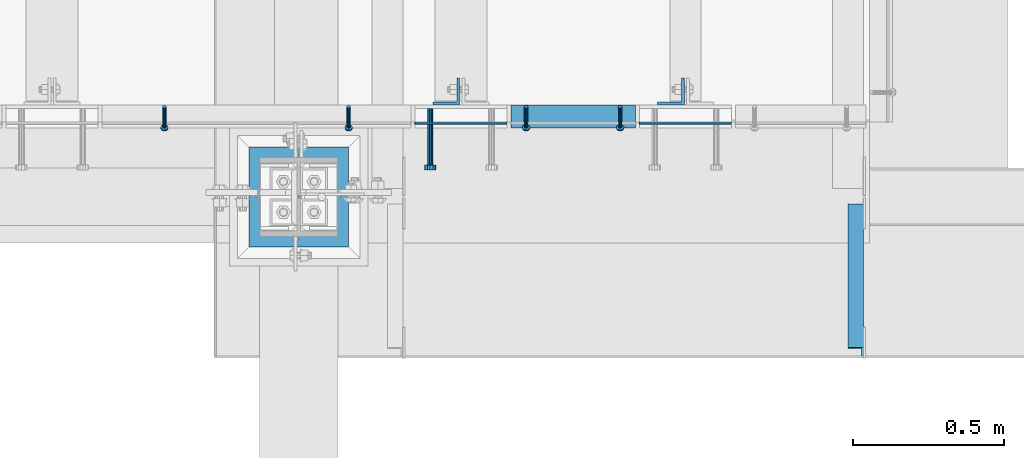
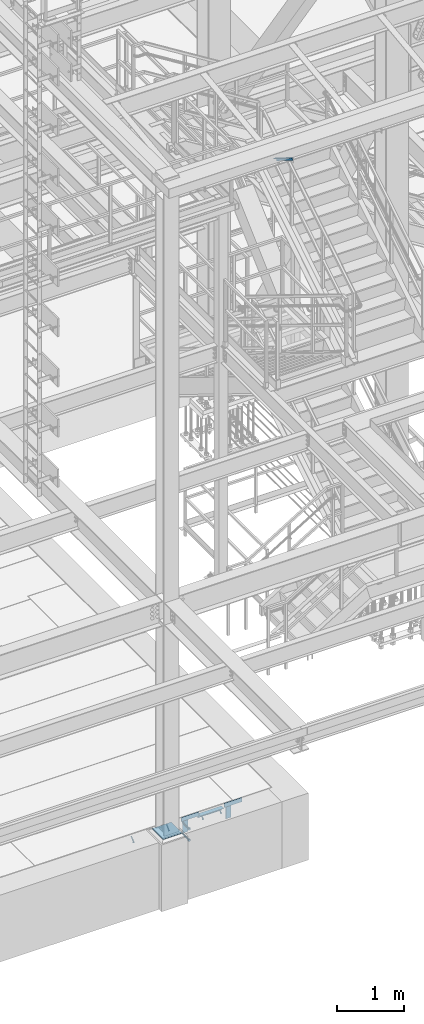
# One storey, part 2040 of 3843: 8 beams, 5 members, 8 elements without a shape of their own.
"""IFC2X3 building model written with IfcOpenShell, lengths in millimetres."""

from ifc_helpers import new_model, si_unit, frame, origin_with_axes, place, context, subcontext, project, spatial, faceted_brep, material, type_object, element, aggregate, save


model = new_model("IFC2X3")

# Units and contexts
model_context = context("Model", 3, precision=1e-05, world=origin_with_axes())
body_context = subcontext(model_context, "Body", "Model", "MODEL_VIEW")
ifc_project = project(units=[si_unit("LENGTHUNIT", "METRE", prefix="MILLI"), si_unit("AREAUNIT", "SQUARE_METRE"), si_unit("VOLUMEUNIT", "CUBIC_METRE"), si_unit("MASSUNIT", "GRAM", prefix="KILO"), si_unit("TIMEUNIT", "SECOND"), si_unit("PLANEANGLEUNIT", "RADIAN"), si_unit("SOLIDANGLEUNIT", "STERADIAN"), si_unit("THERMODYNAMICTEMPERATUREUNIT", "DEGREE_CELSIUS"), si_unit("LUMINOUSINTENSITYUNIT", "LUMEN")], contexts=[model_context])

# Site, building, storey
site_placement = place(None, origin_with_axes())
site = spatial("IfcSite", under=ifc_project, at=site_placement, CompositionType="ELEMENT")
building_placement = place(site_placement, origin_with_axes())
building = spatial("IfcBuilding", under=site, at=building_placement, Name="Undefined", CompositionType="ELEMENT")
storey_placement = place(building_placement, origin_with_axes())
storey = spatial("IfcBuildingStorey", under=building, at=storey_placement, Name="Undefined", CompositionType="ELEMENT", Elevation=0.0)

# Assembly, members
assembly_1_placement = place(storey_placement, origin_with_axes())
assembly_1 = element("IfcElementAssembly", 1, at=assembly_1_placement, inside=storey, Name="ANGLE", AssemblyPlace="NOTDEFINED", PredefinedType="RIGID_FRAME")
ifc_material_1 = material(Name="STEEL/A108")
member_type_1 = type_object("IfcMemberType", PredefinedType="NOTDEFINED")
member_1_placement = place(assembly_1_placement, frame((49161.7272929978, 15297.1500055596, 30397.4500030518), z_axis=(1.0, 0.0, 0.0), x_axis=(0.0, -0.707106781186548, -0.707106781186548)))
member_1 = element("IfcMember", 2, at=member_1_placement, type_object=member_type_1, material=ifc_material_1, Name="HEADED STUD ANCHOR", context=body_context, shape_type="Brep", body=[
    faceted_brep([(7.27595761418343e-12, -3.18000006675175, 5.5), (0.0, -5.49999999998363, 3.1800000667572), (94.4879985803855, -5.50000000011278, 3.1800000667572), (94.4879985803782, -3.18000006687362, 5.5), (0.0, -6.3499999046162, 0.0), (94.4879985803855, -6.34999990474535, 0.0), (0.0, -5.49999999998363, -3.1800000667572), (94.4879985803855, -5.50000000011278, -3.1800000667572), (7.27595761418343e-12, -3.18000006675175, -5.5), (94.4879985803782, -3.18000006687362, -5.5), (7.27595761418343e-12, -1.81898940354586e-12, -6.34999990463257), (94.4879985803782, -1.20053300634027e-10, -6.34999990463257), (0.0, 3.18000006675175, -5.5), (94.4879985803709, 3.18000006663351, -5.5), (7.27595761418343e-12, 5.49999999998363, -3.1800000667572), (94.4879985803709, 5.49999999987267, -3.1800000667572), (7.27595761418343e-12, 6.3499999046162, 0.0), (94.4879985803673, 6.34999990450706, 0.0), (7.27595761418343e-12, 5.49999999998363, 3.1800000667572), (94.4879985803709, 5.49999999987267, 3.1800000667572), (0.0, 3.18000006675175, 5.5), (94.4879985803709, 3.18000006663351, 5.5), (7.27595761418343e-12, -1.81898940354586e-12, 6.34999990463257), (94.4879985803782, -1.20053300634027e-10, 6.34999990463257), (96.5199985498621, -10.9899997712273, 6.34999990463257), (96.5199985498548, -6.34000015270249, 10.9899997711182), (96.5199985498621, -12.6999998093743, 0.0), (96.5199985498621, -10.9899997712273, -6.34999990463257), (96.5199985498548, -6.34000015270249, -10.9899997711182), (96.5199985498475, -1.21872290037572e-10, -12.6899995803833), (96.5199985498402, 6.34000015245874, -10.9899997711182), (96.519998549833, 10.9899997709817, -6.34999990463257), (96.519998549833, 12.6999998091305, 0.0), (96.519998549833, 10.9899997709817, 6.34999990463257), (96.5199985498402, 6.34000015245874, 10.9899997711182), (96.5199985498475, -1.21872290037572e-10, 12.6899995803833), (101.599998473539, -10.9899997712328, 6.34999990463257), (101.599998473532, -6.34000015270976, 10.9899997711182), (101.599998473539, -12.6999998093797, 0.0), (101.599998473539, -10.9899997712328, -6.34999990463257), (101.599998473532, -6.34000015270976, -10.9899997711182), (101.599998473524, -1.29148247651756e-10, -12.6899995803833), (101.599998473517, 6.34000015245329, -10.9899997711182), (101.59999847351, 10.9899997709763, -6.34999990463257), (101.599998473503, 12.6999998091196, 0.0), (101.59999847351, 10.9899997709763, 6.34999990463257), (101.599998473517, 6.34000015245329, 10.9899997711182), (101.599998473524, -1.29148247651756e-10, 12.6899995803833)], [[[0, 1, 2, 3]], [[1, 4, 5, 2]], [[4, 6, 7, 5]], [[6, 8, 9, 7]], [[8, 10, 11, 9]], [[10, 12, 13, 11]], [[12, 14, 15, 13]], [[14, 16, 17, 15]], [[16, 18, 19, 17]], [[18, 20, 21, 19]], [[20, 22, 23, 21]], [[22, 0, 3, 23]], [[22, 20, 18, 16, 14, 12, 10, 8, 6, 4, 1, 0]], [[3, 2, 24, 25]], [[2, 5, 26, 24]], [[5, 7, 27, 26]], [[7, 9, 28, 27]], [[9, 11, 29, 28]], [[11, 13, 30, 29]], [[13, 15, 31, 30]], [[15, 17, 32, 31]], [[17, 19, 33, 32]], [[19, 21, 34, 33]], [[21, 23, 35, 34]], [[23, 3, 25, 35]], [[25, 24, 36, 37]], [[24, 26, 38, 36]], [[26, 27, 39, 38]], [[27, 28, 40, 39]], [[28, 29, 41, 40]], [[29, 30, 42, 41]], [[30, 31, 43, 42]], [[31, 32, 44, 43]], [[32, 33, 45, 44]], [[33, 34, 46, 45]], [[34, 35, 47, 46]], [[35, 25, 37, 47]], [[38, 39, 40, 41, 42, 43, 44, 45, 46, 47, 37, 36]]]),
])
member_2_placement = place(assembly_1_placement, frame((48552.1272929978, 15297.1500055596, 30397.4500030518), z_axis=(1.0, 0.0, 0.0), x_axis=(0.0, -0.707106781186548, -0.707106781186548)))
member_2 = element("IfcMember", 3, at=member_2_placement, type_object=member_type_1, material=ifc_material_1, Name="HEADED STUD ANCHOR", context=body_context, shape_type="Brep", body=[
    faceted_brep([(7.27595761418343e-12, -3.18000006675175, 5.5), (0.0, -5.49999999998363, 3.1800000667572), (94.4879985803855, -5.50000000011278, 3.1800000667572), (94.4879985803782, -3.18000006687362, 5.5), (0.0, -6.3499999046162, 0.0), (94.4879985803855, -6.34999990474535, 0.0), (0.0, -5.49999999998363, -3.1800000667572), (94.4879985803855, -5.50000000011278, -3.1800000667572), (7.27595761418343e-12, -3.18000006675175, -5.5), (94.4879985803782, -3.18000006687362, -5.5), (7.27595761418343e-12, -1.81898940354586e-12, -6.34999990463257), (94.4879985803782, -1.20053300634027e-10, -6.34999990463257), (0.0, 3.18000006675175, -5.5), (94.4879985803709, 3.18000006663351, -5.5), (7.27595761418343e-12, 5.49999999998363, -3.1800000667572), (94.4879985803709, 5.49999999987267, -3.1800000667572), (7.27595761418343e-12, 6.3499999046162, 0.0), (94.4879985803673, 6.34999990450706, 0.0), (7.27595761418343e-12, 5.49999999998363, 3.1800000667572), (94.4879985803709, 5.49999999987267, 3.1800000667572), (0.0, 3.18000006675175, 5.5), (94.4879985803709, 3.18000006663351, 5.5), (7.27595761418343e-12, -1.81898940354586e-12, 6.34999990463257), (94.4879985803782, -1.20053300634027e-10, 6.34999990463257), (96.5199985498621, -10.9899997712273, 6.34999990463257), (96.5199985498548, -6.34000015270249, 10.9899997711182), (96.5199985498621, -12.6999998093743, 0.0), (96.5199985498621, -10.9899997712273, -6.34999990463257), (96.5199985498548, -6.34000015270249, -10.9899997711182), (96.5199985498475, -1.21872290037572e-10, -12.6899995803833), (96.5199985498402, 6.34000015245874, -10.9899997711182), (96.519998549833, 10.9899997709817, -6.34999990463257), (96.519998549833, 12.6999998091305, 0.0), (96.519998549833, 10.9899997709817, 6.34999990463257), (96.5199985498402, 6.34000015245874, 10.9899997711182), (96.5199985498475, -1.21872290037572e-10, 12.6899995803833), (101.599998473539, -10.9899997712328, 6.34999990463257), (101.599998473532, -6.34000015270976, 10.9899997711182), (101.599998473539, -12.6999998093797, 0.0), (101.599998473539, -10.9899997712328, -6.34999990463257), (101.599998473532, -6.34000015270976, -10.9899997711182), (101.599998473524, -1.29148247651756e-10, -12.6899995803833), (101.599998473517, 6.34000015245329, -10.9899997711182), (101.59999847351, 10.9899997709763, -6.34999990463257), (101.599998473503, 12.6999998091196, 0.0), (101.59999847351, 10.9899997709763, 6.34999990463257), (101.599998473517, 6.34000015245329, 10.9899997711182), (101.599998473524, -1.29148247651756e-10, 12.6899995803833)], [[[0, 1, 2, 3]], [[1, 4, 5, 2]], [[4, 6, 7, 5]], [[6, 8, 9, 7]], [[8, 10, 11, 9]], [[10, 12, 13, 11]], [[12, 14, 15, 13]], [[14, 16, 17, 15]], [[16, 18, 19, 17]], [[18, 20, 21, 19]], [[20, 22, 23, 21]], [[22, 0, 3, 23]], [[22, 20, 18, 16, 14, 12, 10, 8, 6, 4, 1, 0]], [[3, 2, 24, 25]], [[2, 5, 26, 24]], [[5, 7, 27, 26]], [[7, 9, 28, 27]], [[9, 11, 29, 28]], [[11, 13, 30, 29]], [[13, 15, 31, 30]], [[15, 17, 32, 31]], [[17, 19, 33, 32]], [[19, 21, 34, 33]], [[21, 23, 35, 34]], [[23, 3, 25, 35]], [[25, 24, 36, 37]], [[24, 26, 38, 36]], [[26, 27, 39, 38]], [[27, 28, 40, 39]], [[28, 29, 41, 40]], [[29, 30, 42, 41]], [[30, 31, 43, 42]], [[31, 32, 44, 43]], [[32, 33, 45, 44]], [[33, 34, 46, 45]], [[34, 35, 47, 46]], [[35, 25, 37, 47]], [[38, 39, 40, 41, 42, 43, 44, 45, 46, 47, 37, 36]]]),
])
aggregate(assembly_1, [member_1, member_2])

assembly_2_placement = place(storey_placement, origin_with_axes())
assembly_2 = element("IfcElementAssembly", 4, at=assembly_2_placement, inside=storey, Name="ANGLE", AssemblyPlace="NOTDEFINED", PredefinedType="RIGID_FRAME")
member_3_placement = place(assembly_2_placement, frame((49749.0749969224, 15297.1499857906, 30397.4500030518), z_axis=(1.0, 0.0, 0.0), x_axis=(0.0, -0.707106781186548, -0.707106781186548)))
member_3 = element("IfcMember", 5, at=member_3_placement, type_object=member_type_1, material=ifc_material_1, Name="HEADED STUD ANCHOR", context=body_context, shape_type="Brep", body=[
    faceted_brep([(7.27595761418343e-12, -3.18000006675175, 5.5), (0.0, -5.49999999998363, 3.1800000667572), (94.4879985803855, -5.50000000011278, 3.1800000667572), (94.4879985803782, -3.18000006687362, 5.5), (0.0, -6.3499999046162, 0.0), (94.4879985803855, -6.34999990474535, 0.0), (0.0, -5.49999999998363, -3.1800000667572), (94.4879985803855, -5.50000000011278, -3.1800000667572), (7.27595761418343e-12, -3.18000006675175, -5.5), (94.4879985803782, -3.18000006687362, -5.5), (7.27595761418343e-12, -1.81898940354586e-12, -6.34999990463257), (94.4879985803782, -1.20053300634027e-10, -6.34999990463257), (0.0, 3.18000006675175, -5.5), (94.4879985803709, 3.18000006663351, -5.5), (7.27595761418343e-12, 5.49999999998363, -3.1800000667572), (94.4879985803709, 5.49999999987267, -3.1800000667572), (7.27595761418343e-12, 6.3499999046162, 0.0), (94.4879985803673, 6.34999990450706, 0.0), (7.27595761418343e-12, 5.49999999998363, 3.1800000667572), (94.4879985803709, 5.49999999987267, 3.1800000667572), (0.0, 3.18000006675175, 5.5), (94.4879985803709, 3.18000006663351, 5.5), (7.27595761418343e-12, -1.81898940354586e-12, 6.34999990463257), (94.4879985803782, -1.20053300634027e-10, 6.34999990463257), (96.5199985498621, -10.9899997712273, 6.34999990463257), (96.5199985498548, -6.34000015270249, 10.9899997711182), (96.5199985498621, -12.6999998093743, 0.0), (96.5199985498621, -10.9899997712273, -6.34999990463257), (96.5199985498548, -6.34000015270249, -10.9899997711182), (96.5199985498475, -1.21872290037572e-10, -12.6899995803833), (96.5199985498402, 6.34000015245874, -10.9899997711182), (96.519998549833, 10.9899997709817, -6.34999990463257), (96.519998549833, 12.6999998091305, 0.0), (96.519998549833, 10.9899997709817, 6.34999990463257), (96.5199985498402, 6.34000015245874, 10.9899997711182), (96.5199985498475, -1.21872290037572e-10, 12.6899995803833), (101.599998473539, -10.9899997712328, 6.34999990463257), (101.599998473532, -6.34000015270976, 10.9899997711182), (101.599998473539, -12.6999998093797, 0.0), (101.599998473539, -10.9899997712328, -6.34999990463257), (101.599998473532, -6.34000015270976, -10.9899997711182), (101.599998473524, -1.29148247651756e-10, -12.6899995803833), (101.599998473517, 6.34000015245329, -10.9899997711182), (101.59999847351, 10.9899997709763, -6.34999990463257), (101.599998473503, 12.6999998091196, 0.0), (101.59999847351, 10.9899997709763, 6.34999990463257), (101.599998473517, 6.34000015245329, 10.9899997711182), (101.599998473524, -1.29148247651756e-10, 12.6899995803833)], [[[0, 1, 2, 3]], [[1, 4, 5, 2]], [[4, 6, 7, 5]], [[6, 8, 9, 7]], [[8, 10, 11, 9]], [[10, 12, 13, 11]], [[12, 14, 15, 13]], [[14, 16, 17, 15]], [[16, 18, 19, 17]], [[18, 20, 21, 19]], [[20, 22, 23, 21]], [[22, 0, 3, 23]], [[22, 20, 18, 16, 14, 12, 10, 8, 6, 4, 1, 0]], [[3, 2, 24, 25]], [[2, 5, 26, 24]], [[5, 7, 27, 26]], [[7, 9, 28, 27]], [[9, 11, 29, 28]], [[11, 13, 30, 29]], [[13, 15, 31, 30]], [[15, 17, 32, 31]], [[17, 19, 33, 32]], [[19, 21, 34, 33]], [[21, 23, 35, 34]], [[23, 3, 25, 35]], [[25, 24, 36, 37]], [[24, 26, 38, 36]], [[26, 27, 39, 38]], [[27, 28, 40, 39]], [[28, 29, 41, 40]], [[29, 30, 42, 41]], [[30, 31, 43, 42]], [[31, 32, 44, 43]], [[32, 33, 45, 44]], [[33, 34, 46, 45]], [[34, 35, 47, 46]], [[35, 25, 37, 47]], [[38, 39, 40, 41, 42, 43, 44, 45, 46, 47, 37, 36]]]),
])
member_4_placement = place(assembly_2_placement, frame((50060.2249969224, 15297.1499782818, 30397.4500030518), z_axis=(1.0, 0.0, 0.0), x_axis=(0.0, -0.707106781186548, -0.707106781186548)))
member_4 = element("IfcMember", 6, at=member_4_placement, type_object=member_type_1, material=ifc_material_1, Name="HEADED STUD ANCHOR", context=body_context, shape_type="Brep", body=[
    faceted_brep([(7.27595761418343e-12, -3.18000006675175, 5.5), (0.0, -5.49999999998363, 3.1800000667572), (94.4879985803855, -5.50000000011278, 3.1800000667572), (94.4879985803782, -3.18000006687362, 5.5), (0.0, -6.3499999046162, 0.0), (94.4879985803855, -6.34999990474535, 0.0), (0.0, -5.49999999998363, -3.1800000667572), (94.4879985803855, -5.50000000011278, -3.1800000667572), (7.27595761418343e-12, -3.18000006675175, -5.5), (94.4879985803782, -3.18000006687362, -5.5), (7.27595761418343e-12, -1.81898940354586e-12, -6.34999990463257), (94.4879985803782, -1.20053300634027e-10, -6.34999990463257), (0.0, 3.18000006675175, -5.5), (94.4879985803709, 3.18000006663351, -5.5), (7.27595761418343e-12, 5.49999999998363, -3.1800000667572), (94.4879985803709, 5.49999999987267, -3.1800000667572), (7.27595761418343e-12, 6.3499999046162, 0.0), (94.4879985803673, 6.34999990450706, 0.0), (7.27595761418343e-12, 5.49999999998363, 3.1800000667572), (94.4879985803709, 5.49999999987267, 3.1800000667572), (0.0, 3.18000006675175, 5.5), (94.4879985803709, 3.18000006663351, 5.5), (7.27595761418343e-12, -1.81898940354586e-12, 6.34999990463257), (94.4879985803782, -1.20053300634027e-10, 6.34999990463257), (96.5199985498621, -10.9899997712273, 6.34999990463257), (96.5199985498548, -6.34000015270249, 10.9899997711182), (96.5199985498621, -12.6999998093743, 0.0), (96.5199985498621, -10.9899997712273, -6.34999990463257), (96.5199985498548, -6.34000015270249, -10.9899997711182), (96.5199985498475, -1.21872290037572e-10, -12.6899995803833), (96.5199985498402, 6.34000015245874, -10.9899997711182), (96.519998549833, 10.9899997709817, -6.34999990463257), (96.519998549833, 12.6999998091305, 0.0), (96.519998549833, 10.9899997709817, 6.34999990463257), (96.5199985498402, 6.34000015245874, 10.9899997711182), (96.5199985498475, -1.21872290037572e-10, 12.6899995803833), (101.599998473539, -10.9899997712328, 6.34999990463257), (101.599998473532, -6.34000015270976, 10.9899997711182), (101.599998473539, -12.6999998093797, 0.0), (101.599998473539, -10.9899997712328, -6.34999990463257), (101.599998473532, -6.34000015270976, -10.9899997711182), (101.599998473524, -1.29148247651756e-10, -12.6899995803833), (101.599998473517, 6.34000015245329, -10.9899997711182), (101.59999847351, 10.9899997709763, -6.34999990463257), (101.599998473503, 12.6999998091196, 0.0), (101.59999847351, 10.9899997709763, 6.34999990463257), (101.599998473517, 6.34000015245329, 10.9899997711182), (101.599998473524, -1.29148247651756e-10, 12.6899995803833)], [[[0, 1, 2, 3]], [[1, 4, 5, 2]], [[4, 6, 7, 5]], [[6, 8, 9, 7]], [[8, 10, 11, 9]], [[10, 12, 13, 11]], [[12, 14, 15, 13]], [[14, 16, 17, 15]], [[16, 18, 19, 17]], [[18, 20, 21, 19]], [[20, 22, 23, 21]], [[22, 0, 3, 23]], [[22, 20, 18, 16, 14, 12, 10, 8, 6, 4, 1, 0]], [[3, 2, 24, 25]], [[2, 5, 26, 24]], [[5, 7, 27, 26]], [[7, 9, 28, 27]], [[9, 11, 29, 28]], [[11, 13, 30, 29]], [[13, 15, 31, 30]], [[15, 17, 32, 31]], [[17, 19, 33, 32]], [[19, 21, 34, 33]], [[21, 23, 35, 34]], [[23, 3, 25, 35]], [[25, 24, 36, 37]], [[24, 26, 38, 36]], [[26, 27, 39, 38]], [[27, 28, 40, 39]], [[28, 29, 41, 40]], [[29, 30, 42, 41]], [[30, 31, 43, 42]], [[31, 32, 44, 43]], [[32, 33, 45, 44]], [[33, 34, 46, 45]], [[34, 35, 47, 46]], [[35, 25, 37, 47]], [[38, 39, 40, 41, 42, 43, 44, 45, 46, 47, 37, 36]]]),
])

# Assembly, beam
assembly_3_placement = place(storey_placement, origin_with_axes())
assembly_3 = element("IfcElementAssembly", 7, at=assembly_3_placement, inside=storey, Name="EMBED PLATE", AssemblyPlace="NOTDEFINED", PredefinedType="RIGID_FRAME")
ifc_material_2 = material(Name="STEEL/A36")
beam_type_1 = type_object("IfcBeamType", PredefinedType="NOTDEFINED")
beam_1_placement = place(assembly_3_placement, frame((49685.575, 15243.1750030518, 30441.9), z_axis=(0.0, 0.0, 1.0), x_axis=(-1.0, 0.0, 0.0)))
beam_1 = element("IfcBeam", 8, at=beam_1_placement, type_object=beam_type_1, material=ifc_material_2, Name="PLATE", context=body_context, shape_type="Brep", body=[
    faceted_brep([(0.0, 3.17500000000291, -38.0999999999985), (0.0, 3.17500000000291, 38.0999999999985), (304.800000000003, 3.17499999999927, 38.0999999999985), (304.800000000003, 3.17499999999927, -38.0999999999985), (0.0, -3.17500000000291, 38.0999999999985), (304.800000000003, -3.17499999999927, 38.0999999999985), (0.0, -3.17500000000291, -38.0999999999985), (304.800000000003, -3.17499999999927, -38.0999999999985)], [[[0, 1, 2, 3]], [[1, 4, 5, 2]], [[4, 6, 7, 5]], [[6, 0, 3, 7]], [[5, 7, 3, 2]], [[6, 4, 1, 0]]]),
])

assembly_4_placement = place(storey_placement, origin_with_axes())
assembly_4 = element("IfcElementAssembly", 9, at=assembly_4_placement, inside=storey, Name="EMBED PLATE", AssemblyPlace="NOTDEFINED", PredefinedType="RIGID_FRAME")
beam_2_placement = place(assembly_4_placement, frame((50428.525, 15243.1750030518, 30441.9), z_axis=(0.0, 0.0, 1.0), x_axis=(-1.0, 0.0, 0.0)))
beam_2 = element("IfcBeam", 10, at=beam_2_placement, type_object=beam_type_1, material=ifc_material_2, Name="PLATE", context=body_context, shape_type="Brep", body=[
    faceted_brep([(0.0, 3.17500000000291, -38.0999999999985), (0.0, 3.17500000000291, 38.0999999999985), (304.800000000003, 3.17499999999927, 38.0999999999985), (304.800000000003, 3.17499999999927, -38.0999999999985), (0.0, -3.17500000000291, 38.0999999999985), (304.800000000003, -3.17499999999927, 38.0999999999985), (0.0, -3.17500000000291, -38.0999999999985), (304.800000000003, -3.17499999999927, -38.0999999999985)], [[[0, 1, 2, 3]], [[1, 4, 5, 2]], [[4, 6, 7, 5]], [[6, 0, 3, 7]], [[5, 7, 3, 2]], [[6, 4, 1, 0]]]),
])
aggregate(assembly_4, [beam_2])

# Assembly, member
assembly_5_placement = place(storey_placement, origin_with_axes())
assembly_5 = element("IfcElementAssembly", 11, at=assembly_5_placement, inside=storey, Name="ANGLE", AssemblyPlace="NOTDEFINED", PredefinedType="RIGID_FRAME")
ifc_material_3 = material(Name="STEEL/A572-50")
member_type_2 = type_object("IfcMemberType", Name="L2X2X1/4", PredefinedType="NOTDEFINED")
member_5_placement = place(assembly_5_placement, frame((50839.6875, 14962.4615149769, 42136.6100587905), z_axis=(-1.0, 0.0, 0.0), x_axis=(0.0, -0.851012521472712, 0.5251453972917)))
member_5 = element("IfcMember", 12, at=member_5_placement, type_object=member_type_2, material=ifc_material_3, Name="ANGLE", ObjectType="L2X2X1/4", context=body_context, shape_type="Brep", body=[
    faceted_brep([(0.0, 25.4000000000015, -25.4000000000015), (0.0, 25.4000000000015, 25.4000000000015), (558.799999999297, 25.3999999986918, 25.3999999999942), (558.799999999297, 25.3999999986918, -25.3999999999942), (0.0, 19.0500000000029, 25.4000000000015), (558.799999999297, 19.049999998686, 25.3999999999942), (0.0, 19.0500000000029, -19.0499999999993), (558.799999999297, 19.049999998686, -19.0500000000029), (0.0, -25.4000000000015, -19.0499999999993), (558.799999999281, -25.4000000013912, -19.0500000000029), (0.0, -25.4000000000015, -25.4000000000015), (558.799999999281, -25.4000000013912, -25.3999999999942)], [[[0, 1, 2, 3]], [[1, 4, 5, 2]], [[4, 6, 7, 5]], [[6, 8, 9, 7]], [[8, 10, 11, 9]], [[10, 0, 3, 11]], [[5, 7, 9, 11, 3, 2]], [[10, 8, 6, 4, 1, 0]]]),
])
aggregate(assembly_5, [member_5])

# Beam
beam_type_2 = type_object("IfcBeamType", Name="L3X3X1/4", PredefinedType="NOTDEFINED")
beam_3_placement = place(assembly_2_placement, frame((50111.0249771283, 15265.3999475479, 30365.7000030518), z_axis=(0.0, 0.0, -1.0), x_axis=(-1.0, 0.0, 0.0)))
beam_3 = element("IfcBeam", 13, at=beam_3_placement, type_object=beam_type_2, material=ifc_material_2, Name="ANGLE", ObjectType="L3X3X1/4", context=body_context, shape_type="Brep", body=[
    faceted_brep([(0.0, 38.0999999999985, -38.0999999999985), (0.0, 38.0999999999985, 38.0999999999985), (412.750000001892, 38.0999999996438, 38.0999999999985), (412.750000001892, 38.0999999996438, -38.0999999999985), (0.0, 31.75, 38.0999999999985), (412.75000000187, 31.7499999996417, 38.0999999999985), (0.0, 31.75, -31.75), (412.75000000187, 31.7499999996417, -31.75), (0.0, -38.0999999999985, -31.75), (412.750000001688, -38.1000000003733, -31.75), (0.0, -38.0999999999985, -38.0999999999985), (412.750000001688, -38.1000000003733, -38.0999999999985)], [[[0, 1, 2, 3]], [[1, 4, 5, 2]], [[4, 6, 7, 5]], [[6, 8, 9, 7]], [[8, 10, 11, 9]], [[10, 0, 3, 11]], [[5, 7, 9, 11, 3, 2]], [[10, 8, 6, 4, 1, 0]]]),
])

aggregate(assembly_2, [member_3, member_4, beam_3])

# Assembly, beam
assembly_6_placement = place(storey_placement, origin_with_axes())
assembly_6 = element("IfcElementAssembly", 14, at=assembly_6_placement, inside=storey, Name="BEAM", AssemblyPlace="NOTDEFINED", PredefinedType="RIGID_FRAME")
beam_type_3 = type_object("IfcBeamType", Name="L3-1/2X3-1/2X3/8", PredefinedType="NOTDEFINED")
beam_4_placement = place(assembly_6_placement, frame((50228.5, 15347.9500030518, 30365.7), z_axis=(-1.0, 0.0, 0.0), x_axis=(0.0, 0.0, -1.0)))
beam_4 = element("IfcBeam", 15, at=beam_4_placement, type_object=beam_type_3, material=ifc_material_2, Name="ANGLE", ObjectType="L3-1/2X3-1/2X3/8", context=body_context, shape_type="Brep", body=[
    faceted_brep([(-3.63797880709171e-12, 44.4499999999971, -44.4500000000007), (-3.63797880709171e-12, 44.4499999999971, 44.4500000000007), (228.600000000006, 44.4499999999971, 44.4500000000007), (228.600000000006, 44.4499999999971, -44.4500000000007), (0.0, 34.9250000000029, 44.4500000000007), (228.600000000006, 34.9250000000029, 44.4500000000007), (0.0, 34.9250000000029, -34.9250000000029), (228.600000000006, 34.9250000000029, -34.9249999999993), (0.0, -44.4499999999971, -34.9249999999993), (228.600000000006, -44.4499999999971, -34.9249999999993), (3.63797880709171e-12, -44.4499999999971, -44.4500000000007), (228.600000000006, -44.4499999999971, -44.4500000000007)], [[[0, 1, 2, 3]], [[1, 4, 5, 2]], [[4, 6, 7, 5]], [[6, 8, 9, 7]], [[8, 10, 11, 9]], [[10, 0, 3, 11]], [[5, 7, 9, 11, 3, 2]], [[10, 8, 6, 4, 1, 0]]]),
])
aggregate(assembly_6, [beam_4])

assembly_7_placement = place(storey_placement, origin_with_axes())
assembly_7 = element("IfcElementAssembly", 16, at=assembly_7_placement, inside=storey, Name="BEAM", AssemblyPlace="NOTDEFINED", PredefinedType="RIGID_FRAME")
beam_5_placement = place(assembly_7_placement, frame((49484.75625, 15347.9500030518, 30365.7), z_axis=(-1.0, 0.0, 0.0), x_axis=(0.0, 0.0, -1.0)))
beam_5 = element("IfcBeam", 17, at=beam_5_placement, type_object=beam_type_3, material=ifc_material_2, Name="ANGLE", ObjectType="L3-1/2X3-1/2X3/8", context=body_context, shape_type="Brep", body=[
    faceted_brep([(-3.63797880709171e-12, 44.4499999999971, -44.4500000000007), (-3.63797880709171e-12, 44.4499999999971, 44.4500000000007), (228.600000000006, 44.4499999999971, 44.4500000000007), (228.600000000006, 44.4499999999971, -44.4500000000007), (0.0, 34.9250000000029, 44.4500000000007), (228.600000000006, 34.9250000000029, 44.4500000000007), (0.0, 34.9250000000029, -34.9250000000029), (228.600000000006, 34.9250000000029, -34.9249999999993), (0.0, -44.4499999999971, -34.9249999999993), (228.600000000006, -44.4499999999971, -34.9249999999993), (3.63797880709171e-12, -44.4499999999971, -44.4500000000007), (228.600000000006, -44.4499999999971, -44.4500000000007)], [[[0, 1, 2, 3]], [[1, 4, 5, 2]], [[4, 6, 7, 5]], [[6, 8, 9, 7]], [[8, 10, 11, 9]], [[10, 0, 3, 11]], [[5, 7, 9, 11, 3, 2]], [[10, 8, 6, 4, 1, 0]]]),
])
aggregate(assembly_7, [beam_5])

# Beam
beam_type_4 = type_object("IfcBeamType", PredefinedType="NOTDEFINED")
beam_6_placement = place(assembly_3_placement, frame((49431.575, 15290.8000030518, 30346.65), z_axis=(1.0, 0.0, 0.0), x_axis=(0.0, -1.0, 0.0)))
beam_6 = element("IfcBeam", 18, at=beam_6_placement, type_object=beam_type_4, material=ifc_material_2, Name="PLATE", context=body_context, shape_type="Brep", body=[
    faceted_brep([(0.0, -9.52000045776367, 0.0), (0.0, -8.25, -4.76000022888184), (184.912000000004, -8.25, -4.76000022888184), (184.912000000004, -9.52000045776367, 0.0), (0.0, -4.76000022888184, -8.25), (184.912000000004, -4.76000022888184, -8.25), (0.0, 0.0, -9.52000045776367), (184.912000000004, 0.0, -9.52000045776367), (0.0, 4.76000022888184, -8.25), (184.912000000004, 4.76000022888184, -8.25), (0.0, 8.25, -4.76000022888184), (184.912000000004, 8.25, -4.76000022888184), (0.0, 9.52000045776367, 0.0), (184.912000000004, 9.52000045776367, 0.0), (0.0, 8.25, 4.76000022888184), (184.912000000004, 8.25, 4.76000022888184), (0.0, 4.76000022888184, 8.25), (184.912000000004, 4.76000022888184, 8.25), (0.0, 0.0, 9.52000045776367), (184.912000000004, 0.0, 9.52000045776367), (0.0, -4.76000022888184, 8.25), (184.912000000004, -4.76000022888184, 8.25), (0.0, -8.25, 4.76000022888184), (184.912000000004, -8.25, 4.76000022888184), (186.944000000003, -16.5, -9.52000045776367), (186.944000000003, -19.0499992370605, 0.0), (186.944000000003, -9.52000045776367, -16.5), (186.944000000003, 0.0, -19.0499992370605), (186.944000000003, 9.52000045776367, -16.5), (186.944000000003, 16.5, -9.52000045776367), (186.944000000003, 19.0499992370605, 0.0), (186.944000000003, 16.5, 9.52000045776367), (186.944000000003, 9.52000045776367, 16.5), (186.944000000003, 0.0, 19.0499992370605), (186.944000000003, -9.52000045776367, 16.5), (186.944000000003, -16.5, 9.52000045776367), (203.199999999997, -16.5, -9.52000045776367), (203.199999999997, -19.0499992370605, 0.0), (203.199999999997, -9.52000045776367, -16.5), (203.199999999997, 0.0, -19.0499992370605), (203.199999999997, 9.52000045776367, -16.5), (203.199999999997, 16.5, -9.52000045776367), (203.199999999997, 19.0499992370605, 0.0), (203.199999999997, 16.5, 9.52000045776367), (203.199999999997, 9.52000045776367, 16.5), (203.199999999997, 0.0, 19.0499992370605), (203.199999999997, -9.52000045776367, 16.5), (203.199999999997, -16.5, 9.52000045776367)], [[[0, 1, 2, 3]], [[1, 4, 5, 2]], [[4, 6, 7, 5]], [[6, 8, 9, 7]], [[8, 10, 11, 9]], [[10, 12, 13, 11]], [[12, 14, 15, 13]], [[14, 16, 17, 15]], [[16, 18, 19, 17]], [[18, 20, 21, 19]], [[20, 22, 23, 21]], [[22, 0, 3, 23]], [[22, 20, 18, 16, 14, 12, 10, 8, 6, 4, 1, 0]], [[3, 2, 24, 25]], [[2, 5, 26, 24]], [[5, 7, 27, 26]], [[7, 9, 28, 27]], [[9, 11, 29, 28]], [[11, 13, 30, 29]], [[13, 15, 31, 30]], [[15, 17, 32, 31]], [[17, 19, 33, 32]], [[19, 21, 34, 33]], [[21, 23, 35, 34]], [[23, 3, 25, 35]], [[25, 24, 36, 37]], [[24, 26, 38, 36]], [[26, 27, 39, 38]], [[27, 28, 40, 39]], [[28, 29, 41, 40]], [[29, 30, 42, 41]], [[30, 31, 43, 42]], [[31, 32, 44, 43]], [[32, 33, 45, 44]], [[33, 34, 46, 45]], [[34, 35, 47, 46]], [[35, 25, 37, 47]], [[38, 39, 40, 41, 42, 43, 44, 45, 46, 47, 37, 36]]]),
])

beam_7_placement = place(assembly_3_placement, frame((49431.575, 15290.8000030518, 30143.45), z_axis=(1.0, 0.0, 0.0), x_axis=(0.0, -1.0, 0.0)))
beam_7 = element("IfcBeam", 19, at=beam_7_placement, type_object=beam_type_4, material=ifc_material_1, Name="HEADED STUD ANCHOR", context=body_context, shape_type="Brep", body=[
    faceted_brep([(0.0, -9.52000045776367, 0.0), (0.0, -8.25, -4.76000022888184), (184.912000000004, -8.25, -4.76000022888184), (184.912000000004, -9.52000045776367, 0.0), (0.0, -4.76000022888184, -8.25), (184.912000000004, -4.76000022888184, -8.25), (0.0, 0.0, -9.52000045776367), (184.912000000004, 0.0, -9.52000045776367), (0.0, 4.76000022888184, -8.25), (184.912000000004, 4.76000022888184, -8.25), (0.0, 8.25, -4.76000022888184), (184.912000000004, 8.25, -4.76000022888184), (0.0, 9.52000045776367, 0.0), (184.912000000004, 9.52000045776367, 0.0), (0.0, 8.25, 4.76000022888184), (184.912000000004, 8.25, 4.76000022888184), (0.0, 4.76000022888184, 8.25), (184.912000000004, 4.76000022888184, 8.25), (0.0, 0.0, 9.52000045776367), (184.912000000004, 0.0, 9.52000045776367), (0.0, -4.76000022888184, 8.25), (184.912000000004, -4.76000022888184, 8.25), (0.0, -8.25, 4.76000022888184), (184.912000000004, -8.25, 4.76000022888184), (186.944000000003, -16.5, -9.52000045776367), (186.944000000003, -19.0499992370605, 0.0), (186.944000000003, -9.52000045776367, -16.5), (186.944000000003, 0.0, -19.0499992370605), (186.944000000003, 9.52000045776367, -16.5), (186.944000000003, 16.5, -9.52000045776367), (186.944000000003, 19.0499992370605, 0.0), (186.944000000003, 16.5, 9.52000045776367), (186.944000000003, 9.52000045776367, 16.5), (186.944000000003, 0.0, 19.0499992370605), (186.944000000003, -9.52000045776367, 16.5), (186.944000000003, -16.5, 9.52000045776367), (203.199999999997, -16.5, -9.52000045776367), (203.199999999997, -19.0499992370605, 0.0), (203.199999999997, -9.52000045776367, -16.5), (203.199999999997, 0.0, -19.0499992370605), (203.199999999997, 9.52000045776367, -16.5), (203.199999999997, 16.5, -9.52000045776367), (203.199999999997, 19.0499992370605, 0.0), (203.199999999997, 16.5, 9.52000045776367), (203.199999999997, 9.52000045776367, 16.5), (203.199999999997, 0.0, 19.0499992370605), (203.199999999997, -9.52000045776367, 16.5), (203.199999999997, -16.5, 9.52000045776367)], [[[0, 1, 2, 3]], [[1, 4, 5, 2]], [[4, 6, 7, 5]], [[6, 8, 9, 7]], [[8, 10, 11, 9]], [[10, 12, 13, 11]], [[12, 14, 15, 13]], [[14, 16, 17, 15]], [[16, 18, 19, 17]], [[18, 20, 21, 19]], [[20, 22, 23, 21]], [[22, 0, 3, 23]], [[22, 20, 18, 16, 14, 12, 10, 8, 6, 4, 1, 0]], [[3, 2, 24, 25]], [[2, 5, 26, 24]], [[5, 7, 27, 26]], [[7, 9, 28, 27]], [[9, 11, 29, 28]], [[11, 13, 30, 29]], [[13, 15, 31, 30]], [[15, 17, 32, 31]], [[17, 19, 33, 32]], [[19, 21, 34, 33]], [[21, 23, 35, 34]], [[23, 3, 25, 35]], [[25, 24, 36, 37]], [[24, 26, 38, 36]], [[26, 27, 39, 38]], [[27, 28, 40, 39]], [[28, 29, 41, 40]], [[29, 30, 42, 41]], [[30, 31, 43, 42]], [[31, 32, 44, 43]], [[32, 33, 45, 44]], [[33, 34, 46, 45]], [[34, 35, 47, 46]], [[35, 25, 37, 47]], [[38, 39, 40, 41, 42, 43, 44, 45, 46, 47, 37, 36]]]),
])

aggregate(assembly_3, [beam_1, beam_6, beam_7])

# Assembly, beam
assembly_8_placement = place(storey_placement, origin_with_axes())
assembly_8 = element("IfcElementAssembly", 20, at=assembly_8_placement, inside=storey, Name="TEMPLATE", AssemblyPlace="NOTDEFINED", PredefinedType="RIGID_FRAME")
beam_type_5 = type_object("IfcBeamType", PredefinedType="NOTDEFINED")
beam_8_placement = place(assembly_8_placement, frame((48996.6, 14833.6000007629, 30520.4815), z_axis=(-1.0, 0.0, 0.0), x_axis=(0.0, 1.0, 0.0)))
beam_8 = element("IfcBeam", 21, at=beam_8_placement, type_object=beam_type_5, material=ifc_material_3, Name="TEMPLATE", context=body_context, shape_type="Brep", body=[
    faceted_brep([(0.0, 2.38149999999951, -165.100000000006), (0.0, 2.38149999999951, 165.100000000006), (330.199996948242, 2.38149999999951, 165.100000000006), (330.199996948242, 2.38149999999951, -165.100000000006), (0.0, -2.38149999999951, 165.100000000006), (330.199996948242, -2.38149999999951, 165.100000000006), (0.0, -2.38149999999951, -165.100000000006), (330.199996948242, -2.38149999999951, -165.100000000006)], [[[0, 1, 2, 3]], [[1, 4, 5, 2]], [[4, 6, 7, 5]], [[6, 0, 3, 7]], [[5, 7, 3, 2]], [[6, 4, 1, 0]]]),
])
aggregate(assembly_8, [beam_8])

save(model, "model.ifc")
